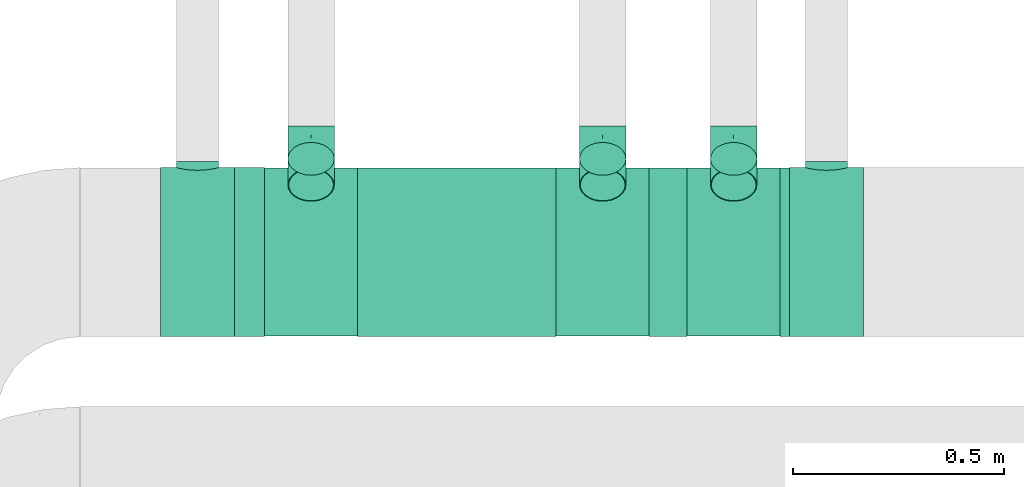
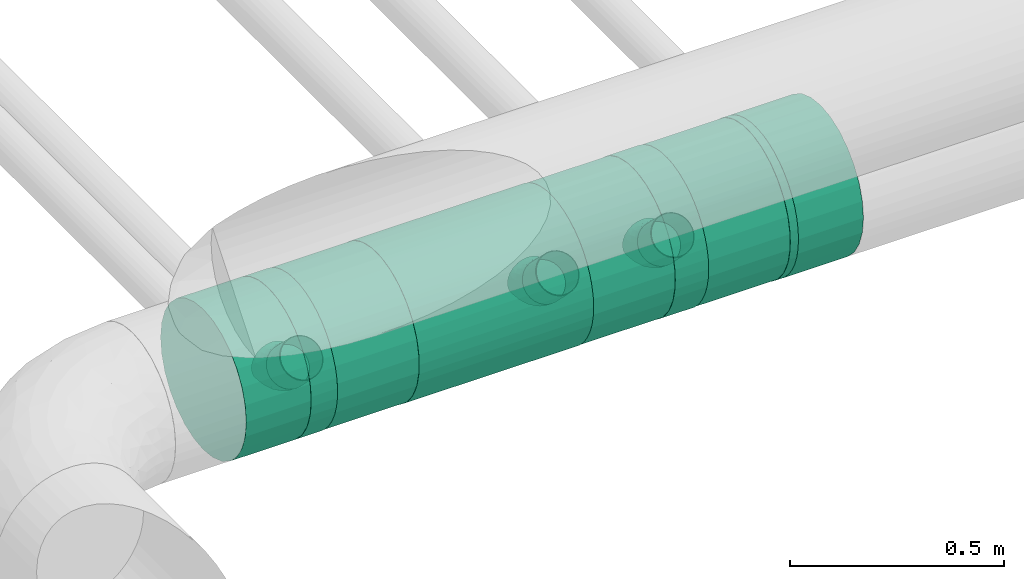
# One storey, part 70 of 91: 8 flow fittings, 7 flow segments.
"""IFC2X3 building model written with IfcOpenShell, lengths in millimetres."""

from ifc_helpers import new_model, entity, si_unit, converted_unit, derived_unit, direction, frame, origin_with_axes, origin_2d_with_axis, place, context, subcontext, project, spatial, hollow_circle, extrude, open_shell, surface_model, source, transform, mapped, material, layer, layer_set, layer_usage, type_object, element, save


model = new_model("IFC2X3")

# Units and contexts
model_context = context("Model", 3, precision=1e-05, world=origin_with_axes(), true_north=direction((0.0, 1.0)))
body_context = subcontext(model_context, "Body", "Model", "MODEL_VIEW")
ifc_project = project(units=[si_unit("AREAUNIT", "SQUARE_METRE"), si_unit("VOLUMEUNIT", "CUBIC_METRE", prefix="DECI"), si_unit("TIMEUNIT", "SECOND"), si_unit("THERMODYNAMICTEMPERATUREUNIT", "DEGREE_CELSIUS"), si_unit("PRESSUREUNIT", "PASCAL"), si_unit("MASSUNIT", "GRAM", prefix="KILO"), si_unit("LENGTHUNIT", "METRE", prefix="MILLI"), si_unit("POWERUNIT", "WATT"), si_unit("ELECTRICCURRENTUNIT", "AMPERE"), si_unit("ELECTRICVOLTAGEUNIT", "VOLT"), derived_unit("VOLUMETRICFLOWRATEUNIT", [(si_unit("VOLUMEUNIT", "CUBIC_METRE", prefix="DECI"), 1), (si_unit("TIMEUNIT", "SECOND"), -1)]), derived_unit("LINEARVELOCITYUNIT", [(si_unit("LENGTHUNIT", "METRE"), 1), (si_unit("TIMEUNIT", "SECOND"), -1)]), derived_unit("MASSDENSITYUNIT", [(si_unit("MASSUNIT", "GRAM", prefix="KILO"), 1), (si_unit("VOLUMEUNIT", "CUBIC_METRE"), -1)]), converted_unit("PLANEANGLEUNIT", "DEGREE", entity("IfcRatioMeasure", 0.01745), si_unit("PLANEANGLEUNIT", "RADIAN"), dimensions=[0, 0, 0, 0, 0, 0, 0])], contexts=[model_context])

# Site, building, storey
site_placement = place(None, origin_with_axes())
site = spatial("IfcSite", under=ifc_project, at=site_placement, CompositionType="ELEMENT")
building_placement = place(site_placement, origin_with_axes())
building = spatial("IfcBuilding", under=site, at=building_placement, Name="mc-building", CompositionType="ELEMENT")
storey_placement = place(building_placement, frame((0.0, 0.0, 8700.0), z_axis=(0.0, 0.0, 1.0), x_axis=(1.0, 0.0, 0.0)))
storey = spatial("IfcBuildingStorey", under=building, at=storey_placement, CompositionType="ELEMENT", Elevation=8700.0)

# Flow fittings
duct_fitting_type_1 = type_object("IfcDuctFittingType", PredefinedType="JUNCTION")
shared_shape_1 = source(origin_with_axes(), body_context, "Body", "SurfaceModel", [
    surface_model("IfcShellBasedSurfaceModel", [(0.0, -225.0, -55.0), (14.23505, -225.0, -53.12592), (-14.23505, -225.0, -53.12592), (-53.12592, -225.0, 14.23505), (-27.5, -225.0, -47.63139), (-47.63139, -225.0, -27.5), (-38.89087, -225.0, -38.89087), (55.0, -225.0, 0.0), (53.12592, -225.0, 14.23505), (38.89087, -225.0, -38.89087), (27.5, -225.0, -47.63139), (53.12592, -225.0, -14.23505), (47.63139, -225.0, -27.5), (-53.12592, -225.0, -14.23505), (-47.63139, -225.0, 27.5), (-38.89087, -225.0, 38.89087), (14.23505, -225.0, 53.12592), (-27.5, -225.0, 47.63139), (-14.23505, -225.0, 53.12592), (47.63139, -225.0, 27.5), (38.89087, -225.0, 38.89087), (27.5, -225.0, 47.63139), (0.0, -225.0, 55.0), (-55.0, -225.0, 0.0), (0.0, -192.28884, 55.0), (-12.29394, -192.68144, 53.60839), (-23.92751, -193.77184, 49.52246), (-34.31923, -195.32745, 42.97895), (-42.9874, -197.03532, 34.30865), (-49.52973, -198.56533, 23.91246), (-53.61252, -199.6229, 12.27592), (-55.0, -200.0, 0.0), (-49.52091, -198.56313, -23.93071), (-42.97449, -197.0325, -34.32482), (-53.60826, -199.62175, -12.29447), (-34.30293, -195.32458, -42.99196), (-23.90904, -193.76957, -49.53138), (-12.27509, -192.68024, -53.61271), (0.0, -192.28884, -55.0), (12.29394, -192.68144, -53.60839), (23.92751, -193.77184, -49.52246), (34.31923, -195.32745, -42.97895), (42.9874, -197.03532, -34.30865), (49.52973, -198.56533, -23.91246), (53.61252, -199.6229, -12.27592), (55.0, -200.0, 0.0), (49.52973, -198.56533, 23.91246), (42.9874, -197.03532, 34.30865), (53.61252, -199.6229, 12.27592), (34.31923, -195.32745, 42.97895), (23.92751, -193.77184, 49.52246), (12.29394, -192.68144, 53.60839), (-110.0, 0.0, -200.0), (-110.0, -44.50419, -194.98559), (-110.0, 44.50419, -194.98559), (-110.0, 194.98559, 44.50419), (-110.0, 86.77674, -180.19378), (-110.0, 180.19378, -86.77674), (-110.0, 156.36629, -124.69796), (-110.0, 124.69796, -156.36629), (-110.0, -200.0, 0.0), (-110.0, -194.98559, 44.50419), (-110.0, -124.69796, -156.36629), (-110.0, -86.77674, -180.19378), (-110.0, -156.36629, -124.69796), (-110.0, -180.19378, -86.77674), (-110.0, -194.98559, -44.50419), (-110.0, 194.98559, -44.50419), (-110.0, 180.19378, 86.77674), (-110.0, 156.36629, 124.69796), (-110.0, 86.77674, 180.19378), (-110.0, 124.69796, 156.36629), (-110.0, 44.50419, 194.98559), (-110.0, 0.0, 200.0), (-110.0, -156.36629, 124.69796), (-110.0, -180.19378, 86.77674), (-110.0, -86.77674, 180.19378), (-110.0, -44.50419, 194.98559), (-110.0, -124.69796, 156.36629), (-110.0, 200.0, 0.0), (110.0, 0.0, -200.0), (110.0, 44.50419, -194.98559), (110.0, 86.77674, -180.19378), (110.0, 200.0, 0.0), (110.0, 156.36629, -124.69796), (110.0, 180.19378, -86.77674), (110.0, 124.69796, -156.36629), (110.0, -156.36629, -124.69796), (110.0, -194.98559, 44.50419), (110.0, -86.77674, -180.19378), (110.0, -44.50419, -194.98559), (110.0, -124.69796, -156.36629), (110.0, -180.19378, -86.77674), (110.0, -194.98559, -44.50419), (110.0, -200.0, 0.0), (110.0, 194.98559, -44.50419), (110.0, 194.98559, 44.50419), (110.0, 180.19378, 86.77674), (110.0, 156.36629, 124.69796), (110.0, 124.69796, 156.36629), (110.0, 86.77674, 180.19378), (110.0, 44.50419, 194.98559), (110.0, -156.36629, 124.69796), (110.0, -180.19378, 86.77674), (110.0, -124.69796, 156.36629), (110.0, -86.77674, 180.19378), (110.0, -44.50419, 194.98559), (110.0, 0.0, 200.0), (-110.0, -197.4928, -22.25209), (110.0, -197.4928, -22.25209), (110.0, -197.4928, 22.25209), (-110.0, -197.4928, 22.25209)], [open_shell([[[0, 1, 2]], [[2, 3, 4]], [[5, 6, 3]], [[6, 4, 3]], [[2, 7, 8]], [[9, 7, 10]], [[1, 10, 7]], [[11, 7, 12]], [[9, 12, 7]], [[7, 2, 1]], [[5, 3, 13]], [[2, 14, 3]], [[2, 15, 14]], [[2, 16, 17]], [[17, 15, 2]], [[16, 18, 17]], [[2, 8, 19]], [[2, 19, 20]], [[2, 20, 21]], [[16, 2, 21]], [[16, 22, 18]], [[23, 13, 3]], [[22, 24, 25]], [[18, 25, 26]], [[22, 25, 18]], [[17, 27, 15]], [[17, 18, 26]], [[27, 17, 26]], [[28, 29, 14]], [[30, 31, 23]], [[29, 30, 3]], [[15, 28, 14]], [[3, 14, 29]], [[23, 3, 30]], [[28, 15, 27]], [[32, 33, 5]], [[34, 32, 13]], [[31, 34, 23]], [[23, 34, 13]], [[32, 5, 13]], [[33, 6, 5]], [[4, 35, 36]], [[36, 37, 2]], [[38, 0, 37]], [[4, 6, 35]], [[2, 4, 36]], [[37, 0, 2]], [[35, 6, 33]], [[0, 38, 39]], [[1, 39, 40]], [[0, 39, 1]], [[10, 41, 9]], [[10, 1, 40]], [[41, 10, 40]], [[42, 43, 12]], [[44, 45, 7]], [[43, 44, 11]], [[9, 42, 12]], [[11, 12, 43]], [[7, 11, 44]], [[42, 9, 41]], [[46, 47, 19]], [[48, 46, 8]], [[45, 48, 7]], [[7, 48, 8]], [[46, 19, 8]], [[47, 20, 19]], [[21, 49, 50]], [[50, 51, 16]], [[24, 22, 51]], [[20, 49, 21]], [[16, 21, 50]], [[22, 16, 51]], [[49, 20, 47]], [[52, 53, 54]], [[54, 55, 56]], [[55, 57, 58]], [[58, 59, 55]], [[59, 56, 55]], [[54, 60, 61]], [[62, 60, 63]], [[54, 53, 63]], [[60, 64, 65]], [[65, 66, 60]], [[60, 62, 64]], [[63, 60, 54]], [[55, 67, 57]], [[54, 68, 55]], [[54, 69, 68]], [[70, 71, 69]], [[70, 54, 72]], [[70, 69, 54]], [[72, 54, 73]], [[74, 73, 75]], [[54, 61, 75]], [[76, 77, 73]], [[73, 78, 76]], [[74, 78, 73]], [[54, 75, 73]], [[79, 67, 55]], [[80, 81, 82]], [[83, 80, 82]], [[84, 85, 83]], [[83, 86, 84]], [[83, 82, 86]], [[87, 80, 88]], [[80, 89, 90]], [[80, 91, 89]], [[91, 80, 87]], [[87, 88, 92]], [[93, 92, 88]], [[93, 88, 94]], [[85, 95, 83]], [[83, 96, 97]], [[98, 80, 97]], [[98, 99, 100]], [[80, 100, 101]], [[80, 98, 100]], [[80, 101, 102]], [[102, 103, 80]], [[88, 80, 103]], [[104, 102, 101]], [[104, 101, 105]], [[101, 106, 105]], [[101, 107, 106]], [[83, 97, 80]], [[72, 107, 101]], [[70, 101, 100]], [[71, 100, 99]], [[73, 107, 72]], [[72, 101, 70]], [[100, 71, 70]], [[99, 69, 71]], [[68, 98, 97]], [[55, 97, 96]], [[79, 96, 83]], [[69, 98, 68]], [[68, 97, 55]], [[96, 79, 55]], [[98, 69, 99]], [[83, 95, 79]], [[85, 84, 58]], [[95, 85, 67]], [[67, 79, 95]], [[58, 57, 85]], [[67, 85, 57]], [[84, 59, 58]], [[56, 86, 82]], [[54, 82, 81]], [[52, 81, 80]], [[59, 86, 56]], [[56, 82, 54]], [[81, 52, 54]], [[86, 59, 84]], [[90, 53, 80]], [[89, 63, 90]], [[65, 87, 92]], [[89, 91, 62]], [[87, 64, 91]], [[92, 40, 39]], [[39, 38, 92]], [[53, 90, 63]], [[62, 63, 89]], [[53, 52, 80]], [[38, 37, 65]], [[34, 108, 32]], [[64, 87, 65]], [[37, 36, 65]], [[64, 62, 91]], [[38, 65, 92]], [[42, 109, 43]], [[93, 42, 41]], [[93, 109, 42]], [[41, 40, 93]], [[93, 40, 92]], [[94, 45, 44]], [[43, 109, 44]], [[44, 109, 94]], [[36, 35, 66]], [[33, 32, 108]], [[33, 66, 35]], [[36, 66, 65]], [[34, 60, 108]], [[31, 60, 34]], [[108, 66, 33]], [[45, 94, 48]], [[94, 110, 48]], [[110, 47, 46]], [[47, 110, 88]], [[49, 47, 88]], [[29, 111, 30]], [[60, 31, 30]], [[111, 60, 30]], [[27, 26, 61]], [[61, 111, 28]], [[61, 28, 27]], [[26, 75, 61]], [[49, 88, 50]], [[51, 103, 24]], [[48, 110, 46]], [[51, 50, 103]], [[74, 103, 102]], [[103, 50, 88]], [[105, 106, 77]], [[76, 104, 105]], [[78, 102, 104]], [[73, 106, 107]], [[25, 24, 75]], [[28, 111, 29]], [[75, 24, 103]], [[74, 75, 103]], [[25, 75, 26]], [[102, 78, 74]], [[104, 76, 78]], [[77, 76, 105]], [[106, 73, 77]]])]),
])
for number, where, z_axis, x_axis in (
    (1, (22757.14677, 10645.73579, 668.0), (0.0, 0.707107, 0.707107), (-1.0, 0.0, 0.0)),
    (2, (23447.14677, 10645.73579, 668.0), (0.0, 0.707107, 0.707107), (-1.0, 0.0, 0.0)),
    (3, (23757.14677, 10645.73579, 668.0), (0.0, 0.707107, 0.707107), (-1.0, 0.0, 0.0)),
):
    element("IfcFlowFitting", number, at=place(storey_placement, frame(where, z_axis=z_axis, x_axis=x_axis)), inside=storey, type_object=duct_fitting_type_1, context=body_context, shape_type="MappedRepresentation", body=[
        mapped(shared_shape_1, transform((0.0, 0.0, 0.0), scale=1.0)),
    ])
duct_fitting_type_2 = type_object("IfcDuctFittingType", Name="BU", PredefinedType="BEND")
shared_shape_2 = source(origin_with_axes(), body_context, "Body", "SurfaceModel", [
    surface_model("IfcShellBasedSurfaceModel", [(-45.56349, 0.0, -55.0), (-45.56349, -14.23505, -53.12592), (-45.56349, 14.23505, -53.12592), (-45.56349, 53.12592, 14.23505), (-45.56349, 27.5, -47.63139), (-45.56349, 38.89087, -38.89087), (-45.56349, 47.63139, -27.5), (-45.56349, -55.0, 0.0), (-45.56349, -53.12592, 14.23505), (-45.56349, -38.89087, -38.89087), (-45.56349, -27.5, -47.63139), (-45.56349, -53.12592, -14.23505), (-45.56349, -47.63139, -27.5), (-45.56349, 53.12592, -14.23505), (-45.56349, 47.63139, 27.5), (-45.56349, 38.89087, 38.89087), (-45.56349, -14.23505, 53.12592), (-45.56349, 27.5, 47.63139), (-45.56349, 14.23505, 53.12592), (-45.56349, -47.63139, 27.5), (-45.56349, -38.89087, 38.89087), (-45.56349, -27.5, 47.63139), (-45.56349, 0.0, 55.0), (-45.56349, 55.0, 0.0), (22.15256, 42.28395, -53.12592), (-6.67262, 71.10913, 0.0), (32.21826, 32.21826, -55.0), (12.77282, 51.66369, -47.63139), (-1.46223, 65.89874, -27.5), (4.71825, 59.71825, -38.89087), (59.71825, 4.71825, -38.89087), (69.78395, -5.34744, 14.23505), (51.66369, 12.77282, -47.63139), (42.28395, 22.15256, -53.12592), (65.89874, -1.46223, -27.5), (69.78395, -5.34744, -14.23505), (71.10913, -6.67262, 0.0), (-5.34744, 69.78395, -14.23505), (-5.34744, 69.78395, 14.23505), (-1.46223, 65.89874, 27.5), (4.71825, 59.71825, 38.89087), (32.21826, 32.21826, 55.0), (12.77282, 51.66369, 47.63139), (22.15256, 42.28395, 53.12592), (59.71825, 4.71825, 38.89087), (65.89874, -1.46223, 27.5), (42.28395, 22.15256, 53.12592), (51.66369, 12.77282, 47.63139), (-20.16649, 48.68621, 33.48188), (-26.97111, 35.77503, 43.63444), (-7.30443, 43.73336, 43.63444), (-17.0934, 3.74816, 55.0), (-18.00408, 15.44793, 53.78143), (-30.11707, 22.39897, 50.81337), (-7.49776, 55.63651, 33.48188), (-15.97018, 58.74288, 21.04759), (-31.18231, 52.58712, 21.04759), (-18.35174, 61.03934, 10.51509), (-28.67677, 56.60048, 10.47121), (-34.03924, 44.64267, 33.48188), (-11.52288, 27.81868, 50.81338), (1.19951, 23.16465, 53.81115), (-33.77926, 57.34403, 0.0), (5.4586, 37.12132, 50.81809), (-24.5159, 59.18663, 0.0), (-16.66281, 64.4339, 0.0), (9.43651, 14.73721, 55.0), (-6.22531, 44.36822, -43.63444), (5.4586, 37.12132, -50.81809), (-34.03924, 44.64267, -33.48188), (9.43651, 14.73721, -55.0), (-17.0934, 3.74816, -55.0), (1.19951, 23.16465, -53.81115), (-11.52288, 27.81868, -50.81338), (-30.11707, 22.39897, -50.81337), (-25.75914, 36.08917, -43.63444), (-30.24487, 52.83011, -21.04759), (-20.16649, 48.68621, -33.48188), (-7.49776, 55.63651, -33.48188), (-18.00408, 15.44793, -53.78143), (-28.68366, 56.62226, -10.35271), (-14.15883, 63.53074, -10.87592), (-15.13548, 59.23394, -21.04759), (3.19797, -7.72059, -52.16847), (3.1272, -18.04126, -47.9241), (13.63233, -32.91136, -32.06475), (45.23618, -22.99734, -20.4997), (16.67434, -40.25541, -15.9539), (-17.3935, -51.68264, -9.80849), (-2.85835, -49.37776, 0.0), (48.84421, -24.24609, -9.80849), (-16.38424, -42.76862, -30.85433), (-6.97383, -29.41689, -42.70541), (41.82739, -18.65658, -30.85433), (-15.72523, -48.24839, -20.4997), (29.28945, -13.63928, -42.80781), (26.81493, -3.56603, -49.15704), (36.93651, -32.89419, 0.0), (-15.72523, -48.24839, 20.4997), (-17.3935, -51.68264, 9.80849), (-16.38424, -42.76862, 30.85433), (16.67434, -40.25541, 15.9539), (3.19797, -7.72059, 52.16847), (10.54583, -14.96836, 47.9241), (13.63233, -32.91136, 32.06475), (45.23618, -22.99734, 20.4997), (41.82739, -18.65658, 30.85433), (-11.06635, -30.3552, 42.80781), (25.73213, -15.86964, 42.70541), (-16.43945, -21.48258, 49.15704), (48.84421, -24.24609, 9.80849)], [open_shell([[[0, 1, 2]], [[2, 3, 4]], [[5, 3, 6]], [[4, 3, 5]], [[2, 7, 8]], [[9, 7, 10]], [[1, 10, 7]], [[11, 7, 12]], [[9, 12, 7]], [[7, 2, 1]], [[13, 6, 3]], [[14, 3, 2]], [[15, 14, 2]], [[16, 17, 2]], [[2, 17, 15]], [[16, 18, 17]], [[19, 20, 2]], [[19, 2, 8]], [[20, 21, 2]], [[2, 21, 16]], [[16, 22, 18]], [[23, 13, 3]], [[24, 25, 26]], [[27, 25, 24]], [[28, 25, 29]], [[29, 25, 27]], [[30, 26, 31]], [[26, 30, 32]], [[32, 33, 26]], [[34, 31, 35]], [[31, 34, 30]], [[35, 31, 36]], [[37, 25, 28]], [[26, 38, 39]], [[26, 39, 40]], [[41, 40, 42]], [[26, 40, 41]], [[42, 43, 41]], [[26, 44, 45]], [[31, 26, 45]], [[46, 47, 26]], [[47, 44, 26]], [[46, 26, 41]], [[26, 25, 38]], [[48, 49, 50]], [[22, 51, 52]], [[17, 49, 15]], [[53, 17, 18]], [[49, 17, 53]], [[54, 50, 40]], [[48, 55, 56]], [[55, 57, 58]], [[59, 14, 15]], [[60, 53, 52]], [[50, 49, 60]], [[58, 3, 56]], [[52, 51, 61]], [[62, 23, 3]], [[63, 50, 60]], [[50, 42, 40]], [[3, 58, 62]], [[43, 61, 41]], [[62, 58, 64]], [[48, 59, 49]], [[14, 56, 3]], [[40, 39, 54]], [[57, 64, 58]], [[39, 38, 55]], [[63, 60, 61]], [[54, 55, 48]], [[65, 57, 38]], [[56, 14, 59]], [[38, 25, 65]], [[60, 52, 61]], [[49, 59, 15]], [[55, 58, 56]], [[56, 59, 48]], [[55, 54, 39]], [[50, 54, 48]], [[18, 22, 52]], [[49, 53, 60]], [[18, 52, 53]], [[61, 51, 66]], [[41, 61, 66]], [[63, 61, 43]], [[43, 42, 63]], [[50, 63, 42]], [[38, 57, 55]], [[64, 57, 65]], [[67, 27, 68]], [[69, 5, 6]], [[70, 71, 72]], [[73, 74, 75]], [[76, 77, 69]], [[29, 78, 28]], [[2, 79, 0]], [[13, 23, 62]], [[2, 74, 79]], [[5, 75, 4]], [[77, 78, 67]], [[13, 62, 80]], [[64, 80, 62]], [[81, 80, 64]], [[67, 73, 75]], [[82, 77, 76]], [[81, 64, 65]], [[76, 69, 6]], [[82, 76, 80]], [[24, 72, 68]], [[74, 2, 4]], [[27, 67, 29]], [[26, 70, 72]], [[69, 75, 5]], [[82, 28, 78]], [[72, 71, 79]], [[6, 13, 76]], [[77, 67, 75]], [[13, 80, 76]], [[82, 37, 28]], [[81, 25, 37]], [[82, 81, 37]], [[75, 69, 77]], [[67, 78, 29]], [[82, 78, 77]], [[75, 74, 4]], [[79, 74, 73]], [[79, 73, 72]], [[79, 71, 0]], [[68, 72, 73]], [[26, 72, 24]], [[67, 68, 73]], [[27, 24, 68]], [[80, 81, 82]], [[25, 81, 65]], [[1, 83, 84]], [[85, 86, 87]], [[0, 71, 1]], [[88, 87, 89]], [[90, 86, 35]], [[91, 92, 85]], [[11, 88, 7]], [[30, 34, 93]], [[11, 12, 94]], [[92, 91, 9]], [[85, 94, 91]], [[94, 85, 87]], [[95, 93, 85]], [[85, 92, 95]], [[83, 71, 70]], [[12, 9, 91]], [[70, 26, 33]], [[96, 84, 83]], [[1, 71, 83]], [[95, 96, 32]], [[95, 30, 93]], [[95, 32, 30]], [[97, 89, 87]], [[34, 86, 93]], [[36, 97, 90]], [[94, 88, 11]], [[34, 35, 86]], [[90, 87, 86]], [[93, 86, 85]], [[32, 96, 33]], [[84, 10, 1]], [[33, 83, 70]], [[94, 12, 91]], [[10, 92, 9]], [[87, 88, 94]], [[7, 88, 89]], [[36, 90, 35]], [[87, 90, 97]], [[84, 95, 92]], [[33, 96, 83]], [[95, 84, 96]], [[10, 84, 92]], [[8, 98, 19]], [[7, 89, 99]], [[19, 98, 100]], [[101, 98, 99]], [[46, 102, 103]], [[104, 105, 106]], [[100, 98, 104]], [[107, 104, 108]], [[16, 51, 22]], [[51, 16, 102]], [[107, 20, 100]], [[107, 109, 21]], [[21, 20, 107]], [[103, 47, 46]], [[101, 89, 97]], [[105, 110, 31]], [[44, 47, 108]], [[105, 104, 101]], [[107, 100, 104]], [[31, 110, 36]], [[109, 16, 21]], [[108, 106, 44]], [[105, 45, 106]], [[41, 66, 46]], [[102, 66, 51]], [[46, 66, 102]], [[104, 98, 101]], [[99, 98, 8]], [[106, 108, 104]], [[110, 101, 97]], [[45, 44, 106]], [[105, 31, 45]], [[20, 19, 100]], [[109, 103, 102]], [[101, 110, 105]], [[36, 110, 97]], [[7, 99, 8]], [[101, 99, 89]], [[103, 107, 108]], [[16, 109, 102]], [[107, 103, 109]], [[47, 103, 108]]])]),
])
for number, where, z_axis, x_axis, name in (
    (4, (22757.14677, 10898.73579, 415.0), (-1.0, 0.0, 0.0), (0.0, -1.0, 0.0), "BU"),
    (5, (23447.14677, 10898.73579, 415.0), (-1.0, 0.0, 0.0), (0.0, -1.0, 0.0), "BU"),
    (6, (23757.14677, 10898.73579, 415.0), (-1.0, 0.0, 0.0), (0.0, -1.0, 0.0), "BU"),
):
    element("IfcFlowFitting", number, at=place(storey_placement, frame(where, z_axis=z_axis, x_axis=x_axis)), inside=storey, type_object=duct_fitting_type_2, Name=name, context=body_context, shape_type="MappedRepresentation", body=[
        mapped(shared_shape_2, transform((0.0, 0.0, 0.0), scale=1.0)),
    ])
shared_shape_3 = source(origin_with_axes(), body_context, "Body", "SurfaceModel", [
    surface_model("IfcShellBasedSurfaceModel", [(0.0, -214.99999, -50.0), (12.94095, -214.99999, -48.29629), (-12.94095, -214.99999, -48.29629), (-48.29629, -214.99999, 12.94095), (-25.0, -214.99999, -43.30127), (-35.35534, -214.99999, -35.35534), (-43.30127, -214.99999, -25.0), (50.0, -214.99999, 0.0), (48.29629, -214.99999, 12.94095), (35.35534, -214.99999, -35.35534), (25.0, -214.99999, -43.30127), (48.29629, -214.99999, -12.94095), (43.30127, -214.99999, -25.0), (-48.29629, -214.99999, -12.94095), (-43.30127, -214.99999, 25.0), (-35.35534, -214.99999, 35.35534), (-25.0, -214.99999, 43.30127), (12.94095, -214.99999, 48.29629), (-12.94095, -214.99999, 48.29629), (43.30127, -214.99999, 25.0), (35.35534, -214.99999, 35.35534), (25.0, -214.99999, 43.30127), (0.0, -214.99999, 50.0), (-50.0, -214.99999, 0.0), (0.0, -193.64917, 50.0), (-11.1705, -193.97108, 48.73623), (-21.74582, -194.86632, 45.02354), (-31.19769, -196.14611, 39.07306), (-39.08243, -197.55364, 31.18594), (-45.03009, -198.81577, 21.73227), (-48.73904, -199.6885, 11.15822), (-50.0, -200.0, 0.0), (-45.02265, -198.81408, -21.74766), (-39.07054, -197.55128, -31.20084), (-48.73619, -199.68779, -11.17068), (-31.18275, -196.14373, -39.08499), (-21.73037, -194.8646, -45.031), (-11.15801, -193.97036, -48.73909), (0.0, -193.64917, -50.0), (11.1705, -193.97108, -48.73623), (21.74582, -194.86632, -45.02354), (31.19769, -196.14611, -39.07306), (39.08243, -197.55364, -31.18594), (45.03009, -198.81577, -21.73227), (48.73904, -199.6885, -11.15822), (50.0, -200.0, 0.0), (45.03009, -198.81577, 21.73227), (39.08243, -197.55364, 31.18594), (48.73904, -199.6885, 11.15822), (31.19769, -196.14611, 39.07306), (21.74582, -194.86632, 45.02354), (11.1705, -193.97108, 48.73623), (-87.5, 0.0, -200.0), (-87.5, -44.50419, -194.98559), (-87.5, 44.50419, -194.98559), (-87.5, 194.98559, 44.50419), (-87.5, 86.77674, -180.19378), (-87.5, 180.19378, -86.77674), (-87.5, 156.36629, -124.69796), (-87.5, 124.69796, -156.36629), (-87.5, -200.0, 0.0), (-87.5, -194.98559, 44.50419), (-87.5, -124.69796, -156.36629), (-87.5, -86.77674, -180.19378), (-87.5, -156.36629, -124.69796), (-87.5, -180.19378, -86.77674), (-87.5, -194.98559, -44.50419), (-87.5, 194.98559, -44.50419), (-87.5, 180.19378, 86.77674), (-87.5, 156.36629, 124.69796), (-87.5, 86.77674, 180.19378), (-87.5, 124.69796, 156.36629), (-87.5, 44.50419, 194.98559), (-87.5, 0.0, 200.0), (-87.5, -156.36629, 124.69796), (-87.5, -180.19378, 86.77674), (-87.5, -86.77674, 180.19378), (-87.5, -44.50419, 194.98559), (-87.5, -124.69796, 156.36629), (-87.5, 200.0, 0.0), (87.5, 0.0, -200.0), (87.5, 44.50419, -194.98559), (87.5, 86.77674, -180.19378), (87.5, 200.0, 0.0), (87.5, 156.36629, -124.69796), (87.5, 180.19378, -86.77674), (87.5, 124.69796, -156.36629), (87.5, -156.36629, -124.69796), (87.5, -194.98559, 44.50419), (87.5, -86.77674, -180.19378), (87.5, -44.50419, -194.98559), (87.5, -124.69796, -156.36629), (87.5, -180.19378, -86.77674), (87.5, -194.98559, -44.50419), (87.5, -200.0, 0.0), (87.5, 194.98559, -44.50419), (87.5, 194.98559, 44.50419), (87.5, 180.19378, 86.77674), (87.5, 156.36629, 124.69796), (87.5, 124.69796, 156.36629), (87.5, 86.77674, 180.19378), (87.5, 44.50419, 194.98559), (87.5, -156.36629, 124.69796), (87.5, -180.19378, 86.77674), (87.5, -86.77674, 180.19378), (87.5, -124.69796, 156.36629), (87.5, -44.50419, 194.98559), (87.5, 0.0, 200.0), (-87.5, -197.4928, -22.25209), (87.5, -197.4928, -22.25209), (87.5, -197.4928, 22.25209), (-87.5, -197.4928, 22.25209)], [open_shell([[[0, 1, 2]], [[2, 3, 4]], [[5, 3, 6]], [[4, 3, 5]], [[2, 7, 8]], [[9, 7, 10]], [[1, 10, 7]], [[11, 7, 12]], [[9, 12, 7]], [[7, 2, 1]], [[13, 6, 3]], [[14, 3, 2]], [[15, 14, 2]], [[16, 2, 17]], [[16, 15, 2]], [[16, 17, 18]], [[2, 8, 19]], [[2, 19, 20]], [[20, 21, 2]], [[17, 2, 21]], [[17, 22, 18]], [[23, 13, 3]], [[22, 24, 25]], [[18, 25, 26]], [[22, 25, 18]], [[16, 27, 15]], [[16, 18, 26]], [[27, 16, 26]], [[28, 29, 14]], [[30, 31, 23]], [[29, 30, 3]], [[15, 28, 14]], [[3, 14, 29]], [[23, 3, 30]], [[28, 15, 27]], [[32, 33, 6]], [[34, 32, 13]], [[31, 34, 23]], [[23, 34, 13]], [[32, 6, 13]], [[33, 5, 6]], [[4, 35, 36]], [[36, 37, 2]], [[38, 0, 37]], [[5, 35, 4]], [[2, 4, 36]], [[0, 2, 37]], [[35, 5, 33]], [[0, 38, 39]], [[1, 39, 40]], [[0, 39, 1]], [[10, 41, 9]], [[10, 1, 40]], [[41, 10, 40]], [[42, 43, 12]], [[44, 45, 7]], [[43, 44, 11]], [[9, 42, 12]], [[11, 12, 43]], [[7, 11, 44]], [[42, 9, 41]], [[46, 47, 19]], [[48, 46, 8]], [[45, 48, 7]], [[7, 48, 8]], [[46, 19, 8]], [[47, 20, 19]], [[21, 49, 50]], [[50, 51, 17]], [[24, 22, 51]], [[20, 49, 21]], [[17, 21, 50]], [[22, 17, 51]], [[49, 20, 47]], [[52, 53, 54]], [[54, 55, 56]], [[55, 57, 58]], [[58, 59, 55]], [[56, 55, 59]], [[54, 60, 61]], [[62, 60, 63]], [[54, 53, 63]], [[60, 64, 65]], [[65, 66, 60]], [[60, 62, 64]], [[63, 60, 54]], [[67, 57, 55]], [[55, 54, 68]], [[68, 54, 69]], [[70, 71, 69]], [[72, 70, 54]], [[70, 69, 54]], [[73, 72, 54]], [[74, 73, 75]], [[54, 61, 75]], [[76, 77, 73]], [[73, 78, 76]], [[74, 78, 73]], [[54, 75, 73]], [[79, 67, 55]], [[80, 81, 82]], [[83, 80, 82]], [[84, 85, 83]], [[83, 86, 84]], [[86, 83, 82]], [[87, 80, 88]], [[80, 89, 90]], [[80, 91, 89]], [[91, 80, 87]], [[87, 88, 92]], [[93, 92, 88]], [[93, 88, 94]], [[83, 85, 95]], [[83, 96, 97]], [[98, 80, 97]], [[99, 100, 80]], [[80, 100, 101]], [[98, 99, 80]], [[80, 101, 102]], [[102, 103, 80]], [[88, 80, 103]], [[101, 104, 105]], [[102, 101, 105]], [[106, 104, 101]], [[107, 106, 101]], [[83, 97, 80]], [[72, 107, 101]], [[70, 101, 100]], [[71, 100, 99]], [[73, 107, 72]], [[72, 101, 70]], [[100, 71, 70]], [[99, 69, 71]], [[68, 98, 97]], [[55, 97, 96]], [[79, 96, 83]], [[69, 98, 68]], [[68, 97, 55]], [[96, 79, 55]], [[98, 69, 99]], [[83, 95, 79]], [[85, 84, 58]], [[95, 85, 57]], [[67, 79, 95]], [[58, 57, 85]], [[67, 95, 57]], [[84, 59, 58]], [[56, 86, 82]], [[54, 82, 81]], [[52, 81, 80]], [[59, 86, 56]], [[56, 82, 54]], [[81, 52, 54]], [[86, 59, 84]], [[90, 53, 80]], [[89, 63, 90]], [[65, 87, 92]], [[89, 91, 62]], [[87, 64, 91]], [[92, 93, 39]], [[39, 38, 92]], [[53, 90, 63]], [[62, 63, 89]], [[53, 52, 80]], [[38, 37, 65]], [[34, 108, 32]], [[64, 87, 65]], [[37, 66, 65]], [[64, 62, 91]], [[38, 65, 92]], [[42, 109, 43]], [[93, 42, 41]], [[93, 109, 42]], [[41, 40, 93]], [[93, 40, 39]], [[94, 45, 44]], [[43, 109, 44]], [[44, 109, 94]], [[36, 35, 66]], [[33, 32, 108]], [[33, 66, 35]], [[36, 66, 37]], [[34, 60, 108]], [[31, 60, 34]], [[108, 66, 33]], [[45, 94, 48]], [[94, 110, 48]], [[110, 47, 46]], [[47, 110, 88]], [[49, 47, 88]], [[29, 111, 30]], [[60, 31, 30]], [[111, 60, 30]], [[27, 26, 61]], [[61, 111, 28]], [[61, 28, 27]], [[26, 25, 61]], [[49, 88, 50]], [[51, 103, 24]], [[48, 110, 46]], [[50, 88, 51]], [[74, 103, 102]], [[51, 88, 103]], [[104, 106, 77]], [[76, 105, 104]], [[78, 102, 105]], [[73, 106, 107]], [[25, 24, 75]], [[28, 111, 29]], [[75, 24, 103]], [[74, 75, 103]], [[25, 75, 61]], [[102, 78, 74]], [[105, 76, 78]], [[77, 76, 104]], [[106, 73, 77]]])]),
])
for number, where, z_axis, x_axis in (
    (7, (22488.52671, 10645.73579, 668.0), (0.0, 0.0, 1.0), (-1.0, 0.0, 0.0)),
    (8, (23976.55606, 10645.73579, 668.0), (0.0, 0.0, 1.0), (-1.0, 0.0, 0.0)),
):
    element("IfcFlowFitting", number, at=place(storey_placement, frame(where, z_axis=z_axis, x_axis=x_axis)), inside=storey, type_object=duct_fitting_type_1, context=body_context, shape_type="MappedRepresentation", body=[
        mapped(shared_shape_3, transform((0.0, 0.0, 0.0), scale=1.0)),
    ])

# Flow segments
ifc_material = material(Name="FZ1")
ifc_layer = layer(ifc_material, 0.0)
ifc_layer_set = layer_set([ifc_layer], Name="FZ1")
ifc_layer_usage = layer_usage(ifc_layer_set, "AXIS1", "POSITIVE", 0.0)
duct_segment_type_1 = type_object("IfcDuctSegmentType", PredefinedType="RIGIDSEGMENT")
shared_shape_4 = source(origin_with_axes(), body_context, "Body", "SweptSolid", [
    extrude(hollow_circle(Radius=55.0, WallThickness=2.0, at=origin_2d_with_axis()), frame((0.0, 0.0, 0.0), z_axis=(1.0, 0.0, 0.0), x_axis=(0.0, 1.0, 0.0)), (0.0, 0.0, 1.0), 87.2),
])
for number, where, z_axis, x_axis in (
    (9, (22757.14677, 10804.83482, 508.90097), (0.0, -0.707107, -0.707107), (0.0, 0.707107, -0.707107)),
    (10, (23447.14677, 10804.83482, 508.90097), (0.0, -0.707107, -0.707107), (0.0, 0.707107, -0.707107)),
    (11, (23757.14677, 10804.83482, 508.90097), (0.0, -0.707107, -0.707107), (0.0, 0.707107, -0.707107)),
):
    element("IfcFlowSegment", number, at=place(storey_placement, frame(where, z_axis=z_axis, x_axis=x_axis)), inside=storey, type_object=duct_segment_type_1, material=ifc_layer_usage, context=body_context, shape_type="MappedRepresentation", body=[
        mapped(shared_shape_4, transform((0.0, 0.0, 0.0), scale=1.0)),
    ])
duct_segment_type_2 = type_object("IfcDuctSegmentType", Name="Safe", PredefinedType="RIGIDSEGMENT")
shared_shape_5 = source(origin_with_axes(), body_context, "Body", "SweptSolid", [
    extrude(hollow_circle(Radius=200.0, WallThickness=2.0, at=origin_2d_with_axis()), frame((0.0, 0.0, 0.0), z_axis=(1.0, 0.0, 0.0), x_axis=(0.0, 1.0, 0.0)), (0.0, 0.0, 1.0), 71.1),
])
flow_segment_1_placement = place(storey_placement, frame((22647.14677, 10645.73579, 668.0), z_axis=(0.0, -0.707107, 0.707107), x_axis=(-1.0, 0.0, 0.0)))
element("IfcFlowSegment", 12, at=flow_segment_1_placement, inside=storey, type_object=duct_segment_type_2, material=ifc_layer_usage, Name="Safe", context=body_context, shape_type="MappedRepresentation", body=[
    mapped(shared_shape_5, transform((0.0, 0.0, 0.0), scale=1.0)),
])
shared_shape_6 = source(origin_with_axes(), body_context, "Body", "SweptSolid", [
    extrude(hollow_circle(Radius=200.0, WallThickness=2.0, at=origin_2d_with_axis()), frame((0.0, 0.0, 0.0), z_axis=(1.0, 0.0, 0.0), x_axis=(0.0, 1.0, 0.0)), (0.0, 0.0, 1.0), 470.0),
])
flow_segment_2_placement = place(storey_placement, frame((23337.14677, 10645.73579, 668.0), z_axis=(0.0, 0.0, 1.0), x_axis=(-1.0, 0.0, 0.0)))
element("IfcFlowSegment", 13, at=flow_segment_2_placement, inside=storey, type_object=duct_segment_type_2, material=ifc_layer_usage, Name="Safe", context=body_context, shape_type="MappedRepresentation", body=[
    mapped(shared_shape_6, transform((0.0, 0.0, 0.0), scale=1.0)),
])
shared_shape_7 = source(origin_with_axes(), body_context, "Body", "SweptSolid", [
    extrude(hollow_circle(Radius=200.0, WallThickness=2.0, at=origin_2d_with_axis()), frame((0.0, 0.0, 0.0), z_axis=(1.0, 0.0, 0.0), x_axis=(0.0, 1.0, 0.0)), (0.0, 0.0, 1.0), 90.0),
])
flow_segment_3_placement = place(storey_placement, frame((23647.14677, 10645.73579, 668.0), z_axis=(0.0, 0.0, 1.0), x_axis=(-1.0, 0.0, 0.0)))
element("IfcFlowSegment", 14, at=flow_segment_3_placement, inside=storey, type_object=duct_segment_type_2, material=ifc_layer_usage, Name="Safe", context=body_context, shape_type="MappedRepresentation", body=[
    mapped(shared_shape_7, transform((0.0, 0.0, 0.0), scale=1.0)),
])
shared_shape_8 = source(origin_with_axes(), body_context, "Body", "SweptSolid", [
    extrude(hollow_circle(Radius=200.0, WallThickness=2.0, at=origin_2d_with_axis()), frame((0.0, 0.0, 0.0), z_axis=(1.0, 0.0, 0.0), x_axis=(0.0, 1.0, 0.0)), (0.0, 0.0, 1.0), 21.9),
])
flow_segment_4_placement = place(storey_placement, frame((23889.05606, 10645.73579, 668.0), z_axis=(0.0, 0.0, 1.0), x_axis=(-1.0, 0.0, 0.0)))
element("IfcFlowSegment", 15, at=flow_segment_4_placement, inside=storey, type_object=duct_segment_type_2, material=ifc_layer_usage, Name="Safe", context=body_context, shape_type="MappedRepresentation", body=[
    mapped(shared_shape_8, transform((0.0, 0.0, 0.0), scale=1.0)),
])

save(model, "model.ifc")
